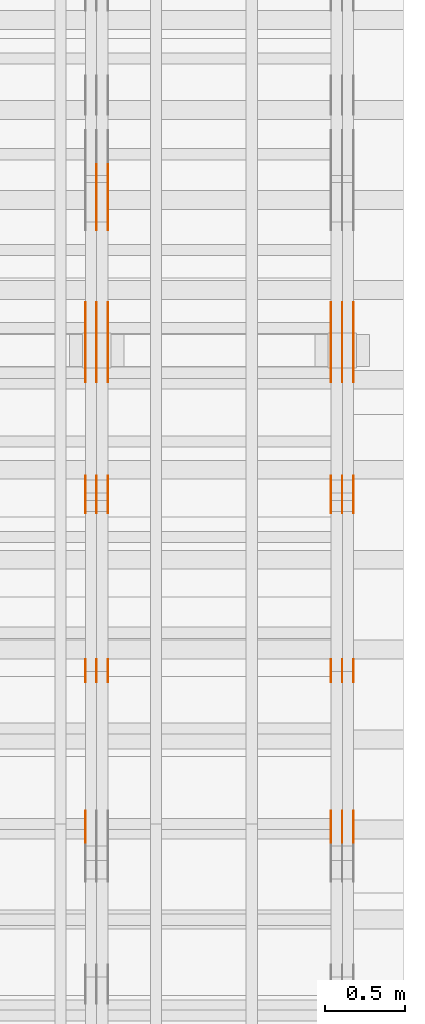
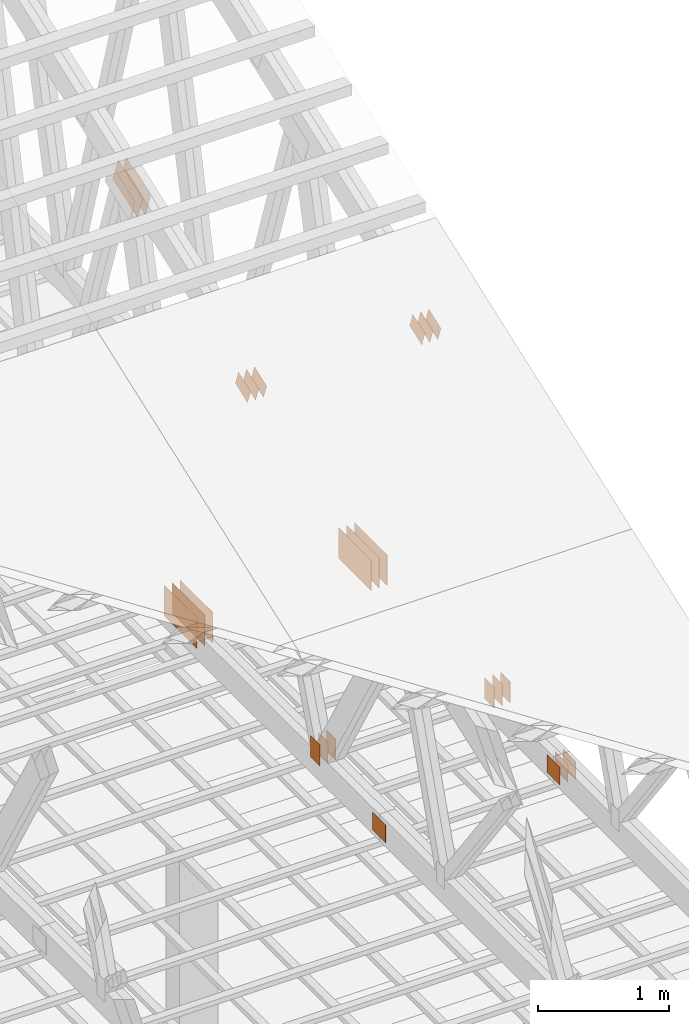
# One storey, part 156 of 189: 32 proxies.
"""IFC2X3 building model written with IfcOpenShell, lengths in millimetres."""

from ifc_helpers import new_model, entity, si_unit, converted_unit, derived_unit, direction, frame, frame_2d, origin, origin_2d_with_axis, place, context, subcontext, project, spatial, polyline, rectangle, outline, extrude, source, transform, mapped, material, type_object, type_shapes, element, save


model = new_model("IFC2X3")

# Units and contexts
model_context = context("Model", 3, precision=0.01, world=origin(), true_north=direction((6.12303176911189e-17, 1.0)))
body_context = subcontext(model_context, "Body", "Model", "MODEL_VIEW")
ifc_project = project(units=[si_unit("LENGTHUNIT", "METRE", prefix="MILLI"), si_unit("AREAUNIT", "SQUARE_METRE"), si_unit("VOLUMEUNIT", "CUBIC_METRE"), converted_unit("PLANEANGLEUNIT", "DEGREE", entity("IfcRatioMeasure", 0.0174532925199433), si_unit("PLANEANGLEUNIT", "RADIAN"), dimensions=[0, 0, 0, 0, 0, 0, 0]), si_unit("MASSUNIT", "GRAM", prefix="KILO"), derived_unit("MASSDENSITYUNIT", [(si_unit("MASSUNIT", "GRAM", prefix="KILO"), 1), (si_unit("LENGTHUNIT", "METRE"), -3)]), si_unit("TIMEUNIT", "SECOND"), si_unit("FREQUENCYUNIT", "HERTZ"), si_unit("THERMODYNAMICTEMPERATUREUNIT", "DEGREE_CELSIUS"), derived_unit("THERMALTRANSMITTANCEUNIT", [(si_unit("MASSUNIT", "GRAM", prefix="KILO"), 1), (si_unit("THERMODYNAMICTEMPERATUREUNIT", "KELVIN"), -1), (si_unit("TIMEUNIT", "SECOND"), -3)]), derived_unit("VOLUMETRICFLOWRATEUNIT", [(si_unit("LENGTHUNIT", "METRE"), 3), (si_unit("TIMEUNIT", "SECOND"), -1)]), si_unit("ELECTRICCURRENTUNIT", "AMPERE"), si_unit("ELECTRICVOLTAGEUNIT", "VOLT"), si_unit("POWERUNIT", "WATT"), si_unit("FORCEUNIT", "NEWTON"), si_unit("ILLUMINANCEUNIT", "LUX"), si_unit("LUMINOUSFLUXUNIT", "LUMEN"), si_unit("LUMINOUSINTENSITYUNIT", "CANDELA"), derived_unit("USERDEFINED", [(si_unit("MASSUNIT", "GRAM", prefix="KILO"), -1), (si_unit("LENGTHUNIT", "METRE"), -2), (si_unit("TIMEUNIT", "SECOND"), 3), (si_unit("LUMINOUSFLUXUNIT", "LUMEN"), 1)]), derived_unit("LINEARVELOCITYUNIT", [(si_unit("LENGTHUNIT", "METRE"), 1), (si_unit("TIMEUNIT", "SECOND"), -1)]), si_unit("PRESSUREUNIT", "PASCAL"), derived_unit("USERDEFINED", [(si_unit("LENGTHUNIT", "METRE"), -2), (si_unit("MASSUNIT", "GRAM", prefix="KILO"), 1), (si_unit("TIMEUNIT", "SECOND"), -2)])], contexts=[model_context])

# Site, building, storey
site_placement = place(None, origin())
site = spatial("IfcSite", under=ifc_project, at=site_placement, CompositionType="ELEMENT")
building_placement = place(site_placement, origin())
building = spatial("IfcBuilding", under=site, at=building_placement, CompositionType="ELEMENT")
storey_placement = place(building_placement, origin())
storey = spatial("IfcBuildingStorey", under=building, at=storey_placement, Name="Default", CompositionType="ELEMENT", Elevation=0.0)

# Proxies
ifc_material_1 = material(Name="IfcSurfaceStyle #284272")
building_element_proxy_type_1 = type_object("IfcBuildingElementProxyType", PredefinedType="NOTDEFINED", material=ifc_material_1)
shared_shape_1 = source(origin(), body_context, "Body", "SweptSolid", [
    extrude(rectangle(XDim=200.0, YDim=144.0, at=frame_2d((1.4210854715202e-14, 0.0), x_axis=(1.0, 0.0))), frame((100.0, 72.0, 0.0), z_axis=(0.0, 0.0, 1.0), x_axis=(-1.0, 0.0, 0.0)), (0.0, 0.0, 1.0), 1.3),
])
type_shapes(building_element_proxy_type_1, [shared_shape_1])
proxy_1_placement = place(building_placement, frame((49841.3, 6668.833984375, 145.0), z_axis=(-1.0, 0.0, 0.0), x_axis=(0.0, 0.0, 1.0)))
element("IfcBuildingElementProxy", 1, at=proxy_1_placement, inside=storey, type_object=building_element_proxy_type_1, material=ifc_material_1, context=body_context, shape_type="MappedRepresentation", body=[
    mapped(shared_shape_1, transform((0.0, 0.0, 0.0), scale=1.0)),
])
ifc_material_2 = material(Name="IfcSurfaceStyle #284215")
building_element_proxy_type_2 = type_object("IfcBuildingElementProxyType", PredefinedType="NOTDEFINED", material=ifc_material_2)
shared_shape_2 = source(origin(), body_context, "Body", "SweptSolid", [
    extrude(rectangle(XDim=200.0, YDim=144.0, at=frame_2d((1.4210854715202e-14, 0.0), x_axis=(1.0, 0.0))), frame((100.0, 72.0, 0.0), z_axis=(0.0, 0.0, 1.0), x_axis=(-1.0, 0.0, 0.0)), (0.0, 0.0, 1.0), 1.29999999999998),
])
type_shapes(building_element_proxy_type_2, [shared_shape_2])
proxy_2_placement = place(building_placement, frame((49770.0, 6668.833984375, 145.0), z_axis=(-1.0, 0.0, 0.0), x_axis=(0.0, 0.0, 1.0)))
element("IfcBuildingElementProxy", 2, at=proxy_2_placement, inside=storey, type_object=building_element_proxy_type_2, material=ifc_material_2, context=body_context, shape_type="MappedRepresentation", body=[
    mapped(shared_shape_2, transform((0.0, 0.0, 0.0), scale=1.0)),
])
ifc_material_3 = material(Name="IfcSurfaceStyle #284158")
building_element_proxy_type_3 = type_object("IfcBuildingElementProxyType", PredefinedType="NOTDEFINED", material=ifc_material_3)
shared_shape_3 = source(origin(), body_context, "Body", "SweptSolid", [
    extrude(rectangle(XDim=200.0, YDim=144.0, at=frame_2d((1.4210854715202e-14, 0.0), x_axis=(1.0, 0.0))), frame((100.0, 72.0, 0.0), z_axis=(0.0, 0.0, 1.0), x_axis=(-1.0, 0.0, 0.0)), (0.0, 0.0, 1.0), 1.29999999999998),
])
type_shapes(building_element_proxy_type_3, [shared_shape_3])
proxy_3_placement = place(building_placement, frame((49771.3, 6668.833984375, 145.0), z_axis=(-1.0, 0.0, 0.0), x_axis=(0.0, 0.0, 1.0)))
element("IfcBuildingElementProxy", 3, at=proxy_3_placement, inside=storey, type_object=building_element_proxy_type_3, material=ifc_material_3, context=body_context, shape_type="MappedRepresentation", body=[
    mapped(shared_shape_3, transform((0.0, 0.0, 0.0), scale=1.0)),
])
ifc_material_4 = material(Name="IfcSurfaceStyle #284101")
building_element_proxy_type_4 = type_object("IfcBuildingElementProxyType", PredefinedType="NOTDEFINED", material=ifc_material_4)
shared_shape_4 = source(origin(), body_context, "Body", "SweptSolid", [
    extrude(rectangle(XDim=200.0, YDim=144.0, at=frame_2d((1.4210854715202e-14, 0.0), x_axis=(1.0, 0.0))), frame((100.0, 72.0, 0.0), z_axis=(0.0, 0.0, 1.0), x_axis=(-1.0, 0.0, 0.0)), (0.0, 0.0, 1.0), 1.29999999999999),
])
type_shapes(building_element_proxy_type_4, [shared_shape_4])
proxy_4_placement = place(building_placement, frame((49700.0, 6668.833984375, 145.0), z_axis=(-1.0, 0.0, 0.0), x_axis=(0.0, 0.0, 1.0)))
element("IfcBuildingElementProxy", 4, at=proxy_4_placement, inside=storey, type_object=building_element_proxy_type_4, material=ifc_material_4, context=body_context, shape_type="MappedRepresentation", body=[
    mapped(shared_shape_4, transform((0.0, 0.0, 0.0), scale=1.0)),
])
ifc_material_5 = material(Name="IfcSurfaceStyle #284044")
building_element_proxy_type_5 = type_object("IfcBuildingElementProxyType", PredefinedType="NOTDEFINED", material=ifc_material_5)
shared_shape_5 = source(origin(), body_context, "Body", "SweptSolid", [
    extrude(rectangle(XDim=200.0, YDim=168.0, at=origin_2d_with_axis()), frame((100.0, 84.0, 0.0), z_axis=(0.0, 0.0, 1.0), x_axis=(-1.0, 0.0, 0.0)), (0.0, 0.0, 1.0), 1.3),
])
type_shapes(building_element_proxy_type_5, [shared_shape_5])
proxy_5_placement = place(building_placement, frame((49841.3, 5662.466796875, 206.5), z_axis=(-1.0, 0.0, 0.0), x_axis=(0.0, 1.0, 0.0)))
element("IfcBuildingElementProxy", 5, at=proxy_5_placement, inside=storey, type_object=building_element_proxy_type_5, material=ifc_material_5, context=body_context, shape_type="MappedRepresentation", body=[
    mapped(shared_shape_5, transform((0.0, 0.0, 0.0), scale=1.0)),
])
ifc_material_6 = material(Name="IfcSurfaceStyle #283987")
building_element_proxy_type_6 = type_object("IfcBuildingElementProxyType", PredefinedType="NOTDEFINED", material=ifc_material_6)
shared_shape_6 = source(origin(), body_context, "Body", "SweptSolid", [
    extrude(rectangle(XDim=200.0, YDim=168.0, at=origin_2d_with_axis()), frame((100.0, 84.0, 0.0), z_axis=(0.0, 0.0, 1.0), x_axis=(-1.0, 0.0, 0.0)), (0.0, 0.0, 1.0), 1.29999999999998),
])
type_shapes(building_element_proxy_type_6, [shared_shape_6])
proxy_6_placement = place(building_placement, frame((49770.0, 5662.466796875, 206.5), z_axis=(-1.0, 0.0, 0.0), x_axis=(0.0, 1.0, 0.0)))
element("IfcBuildingElementProxy", 6, at=proxy_6_placement, inside=storey, type_object=building_element_proxy_type_6, material=ifc_material_6, context=body_context, shape_type="MappedRepresentation", body=[
    mapped(shared_shape_6, transform((0.0, 0.0, 0.0), scale=1.0)),
])
ifc_material_7 = material(Name="IfcSurfaceStyle #283930")
building_element_proxy_type_7 = type_object("IfcBuildingElementProxyType", PredefinedType="NOTDEFINED", material=ifc_material_7)
shared_shape_7 = source(origin(), body_context, "Body", "SweptSolid", [
    extrude(rectangle(XDim=200.0, YDim=168.0, at=origin_2d_with_axis()), frame((100.0, 84.0, 0.0), z_axis=(0.0, 0.0, 1.0), x_axis=(-1.0, 0.0, 0.0)), (0.0, 0.0, 1.0), 1.29999999999998),
])
type_shapes(building_element_proxy_type_7, [shared_shape_7])
proxy_7_placement = place(building_placement, frame((49771.3, 5662.466796875, 206.5), z_axis=(-1.0, 0.0, 0.0), x_axis=(0.0, 1.0, 0.0)))
element("IfcBuildingElementProxy", 7, at=proxy_7_placement, inside=storey, type_object=building_element_proxy_type_7, material=ifc_material_7, context=body_context, shape_type="MappedRepresentation", body=[
    mapped(shared_shape_7, transform((0.0, 0.0, 0.0), scale=1.0)),
])
ifc_material_8 = material(Name="IfcSurfaceStyle #283873")
building_element_proxy_type_8 = type_object("IfcBuildingElementProxyType", PredefinedType="NOTDEFINED", material=ifc_material_8)
shared_shape_8 = source(origin(), body_context, "Body", "SweptSolid", [
    extrude(rectangle(XDim=200.0, YDim=168.0, at=origin_2d_with_axis()), frame((100.0, 84.0, 0.0), z_axis=(0.0, 0.0, 1.0), x_axis=(-1.0, 0.0, 0.0)), (0.0, 0.0, 1.0), 1.29999999999999),
])
type_shapes(building_element_proxy_type_8, [shared_shape_8])
proxy_8_placement = place(building_placement, frame((49700.0, 5662.466796875, 206.5), z_axis=(-1.0, 0.0, 0.0), x_axis=(0.0, 1.0, 0.0)))
element("IfcBuildingElementProxy", 8, at=proxy_8_placement, inside=storey, type_object=building_element_proxy_type_8, material=ifc_material_8, context=body_context, shape_type="MappedRepresentation", body=[
    mapped(shared_shape_8, transform((0.0, 0.0, 0.0), scale=1.0)),
])
ifc_material_9 = material(Name="IfcSurfaceStyle #281308")
building_element_proxy_type_9 = type_object("IfcBuildingElementProxyType", PredefinedType="NOTDEFINED", material=ifc_material_9)
shared_shape_9 = source(origin(), body_context, "Body", "SweptSolid", [
    extrude(rectangle(XDim=500.0, YDim=288.0, at=frame_2d((0.0, 1.4210854715202e-14), x_axis=(1.0, 0.0))), frame((250.000973740011, 144.0, 0.0), z_axis=(0.0, 0.0, 1.0), x_axis=(-1.0, 0.0, 0.0)), (0.0, 0.0, 1.0), 1.29999999999998),
])
type_shapes(building_element_proxy_type_9, [shared_shape_9])
proxy_9_placement = place(building_placement, frame((49841.3, 8551.90918250999, 389.0), z_axis=(-1.0, 0.0, 0.0), x_axis=(0.0, 1.0, 0.0)))
element("IfcBuildingElementProxy", 9, at=proxy_9_placement, inside=storey, type_object=building_element_proxy_type_9, material=ifc_material_9, context=body_context, shape_type="MappedRepresentation", body=[
    mapped(shared_shape_9, transform((0.0, 0.0, 0.0), scale=1.0)),
])
ifc_material_10 = material(Name="IfcSurfaceStyle #281251")
building_element_proxy_type_10 = type_object("IfcBuildingElementProxyType", PredefinedType="NOTDEFINED", material=ifc_material_10)
shared_shape_10 = source(origin(), body_context, "Body", "SweptSolid", [
    extrude(rectangle(XDim=500.0, YDim=288.0, at=frame_2d((0.0, 1.4210854715202e-14), x_axis=(1.0, 0.0))), frame((250.000973740011, 144.0, 0.0), z_axis=(0.0, 0.0, 1.0), x_axis=(-1.0, 0.0, 0.0)), (0.0, 0.0, 1.0), 1.29999999999997),
])
type_shapes(building_element_proxy_type_10, [shared_shape_10])
proxy_10_placement = place(building_placement, frame((49770.0, 8551.90918250999, 389.0), z_axis=(-1.0, 0.0, 0.0), x_axis=(0.0, 1.0, 0.0)))
element("IfcBuildingElementProxy", 10, at=proxy_10_placement, inside=storey, type_object=building_element_proxy_type_10, material=ifc_material_10, context=body_context, shape_type="MappedRepresentation", body=[
    mapped(shared_shape_10, transform((0.0, 0.0, 0.0), scale=1.0)),
])
ifc_material_11 = material(Name="IfcSurfaceStyle #281194")
building_element_proxy_type_11 = type_object("IfcBuildingElementProxyType", PredefinedType="NOTDEFINED", material=ifc_material_11)
shared_shape_11 = source(origin(), body_context, "Body", "SweptSolid", [
    extrude(rectangle(XDim=500.0, YDim=288.0, at=frame_2d((0.0, 1.4210854715202e-14), x_axis=(1.0, 0.0))), frame((250.000973740011, 144.0, 0.0), z_axis=(0.0, 0.0, 1.0), x_axis=(-1.0, 0.0, 0.0)), (0.0, 0.0, 1.0), 1.29999999999997),
])
type_shapes(building_element_proxy_type_11, [shared_shape_11])
proxy_11_placement = place(building_placement, frame((49771.3, 8551.90918250999, 389.0), z_axis=(-1.0, 0.0, 0.0), x_axis=(0.0, 1.0, 0.0)))
element("IfcBuildingElementProxy", 11, at=proxy_11_placement, inside=storey, type_object=building_element_proxy_type_11, material=ifc_material_11, context=body_context, shape_type="MappedRepresentation", body=[
    mapped(shared_shape_11, transform((0.0, 0.0, 0.0), scale=1.0)),
])
ifc_material_12 = material(Name="IfcSurfaceStyle #281137")
building_element_proxy_type_12 = type_object("IfcBuildingElementProxyType", PredefinedType="NOTDEFINED", material=ifc_material_12)
shared_shape_12 = source(origin(), body_context, "Body", "SweptSolid", [
    extrude(rectangle(XDim=500.0, YDim=288.0, at=frame_2d((0.0, 1.4210854715202e-14), x_axis=(1.0, 0.0))), frame((250.000973740011, 144.0, 0.0), z_axis=(0.0, 0.0, 1.0), x_axis=(-1.0, 0.0, 0.0)), (0.0, 0.0, 1.0), 1.29999999999997),
])
type_shapes(building_element_proxy_type_12, [shared_shape_12])
proxy_12_placement = place(building_placement, frame((49700.0, 8551.90918250999, 389.0), z_axis=(-1.0, 0.0, 0.0), x_axis=(0.0, 1.0, 0.0)))
element("IfcBuildingElementProxy", 12, at=proxy_12_placement, inside=storey, type_object=building_element_proxy_type_12, material=ifc_material_12, context=body_context, shape_type="MappedRepresentation", body=[
    mapped(shared_shape_12, transform((0.0, 0.0, 0.0), scale=1.0)),
])
ifc_material_13 = material(Name="IfcSurfaceStyle #281080")
building_element_proxy_type_13 = type_object("IfcBuildingElementProxyType", PredefinedType="NOTDEFINED", material=ifc_material_13)
shared_shape_13 = source(origin(), body_context, "Body", "SweptSolid", [
    extrude(outline(polyline([(-100.00048713087, -72.0000025659129), (100.000394045495, -72.0000025659129), (99.9995694622958, 72.0000025659129), (-99.9994763769209, 72.0000025659128), (-100.00048713087, -72.0000025659129)])), frame((100.000394045495, 72.0000025659128, 0.0), z_axis=(0.0, 0.0, 1.0), x_axis=(-1.0, 0.0, 0.0)), (0.0, 0.0, 1.0), 1.3),
])
type_shapes(building_element_proxy_type_13, [shared_shape_13])
proxy_13_placement = place(building_placement, frame((49841.3, 7965.16887114408, 2936.19963864386), z_axis=(-1.0, 0.0, 0.0), x_axis=(0.0, -0.939692620785908, -0.342020143325669)))
element("IfcBuildingElementProxy", 13, at=proxy_13_placement, inside=storey, type_object=building_element_proxy_type_13, material=ifc_material_13, context=body_context, shape_type="MappedRepresentation", body=[
    mapped(shared_shape_13, transform((0.0, 0.0, 0.0), scale=1.0)),
])
ifc_material_14 = material(Name="IfcSurfaceStyle #281023")
building_element_proxy_type_14 = type_object("IfcBuildingElementProxyType", PredefinedType="NOTDEFINED", material=ifc_material_14)
shared_shape_14 = source(origin(), body_context, "Body", "SweptSolid", [
    extrude(outline(polyline([(-100.00048713087, -72.0000025659129), (100.000394045495, -72.0000025659129), (99.9995694622958, 72.0000025659129), (-99.9994763769209, 72.0000025659128), (-100.00048713087, -72.0000025659129)])), frame((100.000394045495, 72.0000025659128, 0.0), z_axis=(0.0, 0.0, 1.0), x_axis=(-1.0, 0.0, 0.0)), (0.0, 0.0, 1.0), 1.29999999999998),
])
type_shapes(building_element_proxy_type_14, [shared_shape_14])
proxy_14_placement = place(building_placement, frame((49770.0, 7965.16887114408, 2936.19963864386), z_axis=(-1.0, 0.0, 0.0), x_axis=(0.0, -0.939692620785908, -0.342020143325669)))
element("IfcBuildingElementProxy", 14, at=proxy_14_placement, inside=storey, type_object=building_element_proxy_type_14, material=ifc_material_14, context=body_context, shape_type="MappedRepresentation", body=[
    mapped(shared_shape_14, transform((0.0, 0.0, 0.0), scale=1.0)),
])
ifc_material_15 = material(Name="IfcSurfaceStyle #280966")
building_element_proxy_type_15 = type_object("IfcBuildingElementProxyType", PredefinedType="NOTDEFINED", material=ifc_material_15)
shared_shape_15 = source(origin(), body_context, "Body", "SweptSolid", [
    extrude(outline(polyline([(-100.00048713087, -72.0000025659129), (100.000394045495, -72.0000025659129), (99.9995694622958, 72.0000025659129), (-99.9994763769209, 72.0000025659128), (-100.00048713087, -72.0000025659129)])), frame((100.000394045495, 72.0000025659128, 0.0), z_axis=(0.0, 0.0, 1.0), x_axis=(-1.0, 0.0, 0.0)), (0.0, 0.0, 1.0), 1.29999999999998),
])
type_shapes(building_element_proxy_type_15, [shared_shape_15])
proxy_15_placement = place(building_placement, frame((49771.3, 7965.16887114408, 2936.19963864386), z_axis=(-1.0, 0.0, 0.0), x_axis=(0.0, -0.939692620785908, -0.342020143325669)))
element("IfcBuildingElementProxy", 15, at=proxy_15_placement, inside=storey, type_object=building_element_proxy_type_15, material=ifc_material_15, context=body_context, shape_type="MappedRepresentation", body=[
    mapped(shared_shape_15, transform((0.0, 0.0, 0.0), scale=1.0)),
])
ifc_material_16 = material(Name="IfcSurfaceStyle #280909")
building_element_proxy_type_16 = type_object("IfcBuildingElementProxyType", PredefinedType="NOTDEFINED", material=ifc_material_16)
shared_shape_16 = source(origin(), body_context, "Body", "SweptSolid", [
    extrude(outline(polyline([(-100.00048713087, -72.0000025659129), (100.000394045495, -72.0000025659129), (99.9995694622958, 72.0000025659129), (-99.9994763769209, 72.0000025659128), (-100.00048713087, -72.0000025659129)])), frame((100.000394045495, 72.0000025659128, 0.0), z_axis=(0.0, 0.0, 1.0), x_axis=(-1.0, 0.0, 0.0)), (0.0, 0.0, 1.0), 1.29999999999999),
])
type_shapes(building_element_proxy_type_16, [shared_shape_16])
proxy_16_placement = place(building_placement, frame((49700.0, 7965.16887114408, 2936.19963864386), z_axis=(-1.0, 0.0, 0.0), x_axis=(0.0, -0.939692620785908, -0.342020143325669)))
element("IfcBuildingElementProxy", 16, at=proxy_16_placement, inside=storey, type_object=building_element_proxy_type_16, material=ifc_material_16, context=body_context, shape_type="MappedRepresentation", body=[
    mapped(shared_shape_16, transform((0.0, 0.0, 0.0), scale=1.0)),
])
ifc_material_17 = material(Name="IfcSurfaceStyle #268482")
building_element_proxy_type_17 = type_object("IfcBuildingElementProxyType", PredefinedType="NOTDEFINED", material=ifc_material_17)
shared_shape_17 = source(origin(), body_context, "Body", "SweptSolid", [
    extrude(rectangle(XDim=200.0, YDim=144.0, at=frame_2d((1.4210854715202e-14, 0.0), x_axis=(1.0, 0.0))), frame((100.0, 72.0, 0.0), z_axis=(0.0, 0.0, 1.0), x_axis=(-1.0, 0.0, 0.0)), (0.0, 0.0, 1.0), 1.3),
])
type_shapes(building_element_proxy_type_17, [shared_shape_17])
proxy_17_placement = place(building_placement, frame((48301.3, 6668.833984375, 145.0), z_axis=(-1.0, 0.0, 0.0), x_axis=(0.0, 0.0, 1.0)))
element("IfcBuildingElementProxy", 17, at=proxy_17_placement, inside=storey, type_object=building_element_proxy_type_17, material=ifc_material_17, context=body_context, shape_type="MappedRepresentation", body=[
    mapped(shared_shape_17, transform((0.0, 0.0, 0.0), scale=1.0)),
])
ifc_material_18 = material(Name="IfcSurfaceStyle #268425")
building_element_proxy_type_18 = type_object("IfcBuildingElementProxyType", PredefinedType="NOTDEFINED", material=ifc_material_18)
shared_shape_18 = source(origin(), body_context, "Body", "SweptSolid", [
    extrude(rectangle(XDim=200.0, YDim=144.0, at=frame_2d((1.4210854715202e-14, 0.0), x_axis=(1.0, 0.0))), frame((100.0, 72.0, 0.0), z_axis=(0.0, 0.0, 1.0), x_axis=(-1.0, 0.0, 0.0)), (0.0, 0.0, 1.0), 1.29999999999998),
])
type_shapes(building_element_proxy_type_18, [shared_shape_18])
proxy_18_placement = place(building_placement, frame((48230.0, 6668.833984375, 145.0), z_axis=(-1.0, 0.0, 0.0), x_axis=(0.0, 0.0, 1.0)))
element("IfcBuildingElementProxy", 18, at=proxy_18_placement, inside=storey, type_object=building_element_proxy_type_18, material=ifc_material_18, context=body_context, shape_type="MappedRepresentation", body=[
    mapped(shared_shape_18, transform((0.0, 0.0, 0.0), scale=1.0)),
])
ifc_material_19 = material(Name="IfcSurfaceStyle #268368")
building_element_proxy_type_19 = type_object("IfcBuildingElementProxyType", PredefinedType="NOTDEFINED", material=ifc_material_19)
shared_shape_19 = source(origin(), body_context, "Body", "SweptSolid", [
    extrude(rectangle(XDim=200.0, YDim=144.0, at=frame_2d((1.4210854715202e-14, 0.0), x_axis=(1.0, 0.0))), frame((100.0, 72.0, 0.0), z_axis=(0.0, 0.0, 1.0), x_axis=(-1.0, 0.0, 0.0)), (0.0, 0.0, 1.0), 1.29999999999998),
])
type_shapes(building_element_proxy_type_19, [shared_shape_19])
proxy_19_placement = place(building_placement, frame((48231.3, 6668.833984375, 145.0), z_axis=(-1.0, 0.0, 0.0), x_axis=(0.0, 0.0, 1.0)))
element("IfcBuildingElementProxy", 19, at=proxy_19_placement, inside=storey, type_object=building_element_proxy_type_19, material=ifc_material_19, context=body_context, shape_type="MappedRepresentation", body=[
    mapped(shared_shape_19, transform((0.0, 0.0, 0.0), scale=1.0)),
])
ifc_material_20 = material(Name="IfcSurfaceStyle #268311")
building_element_proxy_type_20 = type_object("IfcBuildingElementProxyType", PredefinedType="NOTDEFINED", material=ifc_material_20)
shared_shape_20 = source(origin(), body_context, "Body", "SweptSolid", [
    extrude(rectangle(XDim=200.0, YDim=144.0, at=frame_2d((1.4210854715202e-14, 0.0), x_axis=(1.0, 0.0))), frame((100.0, 72.0, 0.0), z_axis=(0.0, 0.0, 1.0), x_axis=(-1.0, 0.0, 0.0)), (0.0, 0.0, 1.0), 1.29999999999999),
])
type_shapes(building_element_proxy_type_20, [shared_shape_20])
proxy_20_placement = place(building_placement, frame((48160.0, 6668.833984375, 145.0), z_axis=(-1.0, 0.0, 0.0), x_axis=(0.0, 0.0, 1.0)))
element("IfcBuildingElementProxy", 20, at=proxy_20_placement, inside=storey, type_object=building_element_proxy_type_20, material=ifc_material_20, context=body_context, shape_type="MappedRepresentation", body=[
    mapped(shared_shape_20, transform((0.0, 0.0, 0.0), scale=1.0)),
])
ifc_material_21 = material(Name="IfcSurfaceStyle #268083")
building_element_proxy_type_21 = type_object("IfcBuildingElementProxyType", PredefinedType="NOTDEFINED", material=ifc_material_21)
shared_shape_21 = source(origin(), body_context, "Body", "SweptSolid", [
    extrude(rectangle(XDim=200.0, YDim=168.0, at=origin_2d_with_axis()), frame((100.0, 84.0, 0.0), z_axis=(0.0, 0.0, 1.0), x_axis=(-1.0, 0.0, 0.0)), (0.0, 0.0, 1.0), 1.29999999999999),
])
type_shapes(building_element_proxy_type_21, [shared_shape_21])
proxy_21_placement = place(building_placement, frame((48160.0, 5662.466796875, 206.5), z_axis=(-1.0, 0.0, 0.0), x_axis=(0.0, 1.0, 0.0)))
element("IfcBuildingElementProxy", 21, at=proxy_21_placement, inside=storey, type_object=building_element_proxy_type_21, material=ifc_material_21, context=body_context, shape_type="MappedRepresentation", body=[
    mapped(shared_shape_21, transform((0.0, 0.0, 0.0), scale=1.0)),
])
ifc_material_22 = material(Name="IfcSurfaceStyle #266202")
building_element_proxy_type_22 = type_object("IfcBuildingElementProxyType", PredefinedType="NOTDEFINED", material=ifc_material_22)
shared_shape_22 = source(origin(), body_context, "Body", "SweptSolid", [
    extrude(outline(polyline([(-199.999582244654, -119.99984375717), (200.000344770932, -119.99984375717), (199.999582244655, 119.99984375717), (-200.000344770934, 119.99984375717), (-199.999582244654, -119.99984375717)])), frame((200.000344770932, 120.0000091947, 0.0), z_axis=(0.0, 0.0, 1.0), x_axis=(-1.0, 0.0, 0.0)), (0.0, 0.0, 1.0), 1.29999999999999),
])
type_shapes(building_element_proxy_type_22, [shared_shape_22])
proxy_22_placement = place(building_placement, frame((48301.3, 9961.90704972973, 3612.2451494258), z_axis=(-1.0, 0.0, 0.0), x_axis=(0.0, -0.939692620785908, -0.342020143325669)))
element("IfcBuildingElementProxy", 22, at=proxy_22_placement, inside=storey, type_object=building_element_proxy_type_22, material=ifc_material_22, context=body_context, shape_type="MappedRepresentation", body=[
    mapped(shared_shape_22, transform((0.0, 0.0, 0.0), scale=1.0)),
])
ifc_material_23 = material(Name="IfcSurfaceStyle #266145")
building_element_proxy_type_23 = type_object("IfcBuildingElementProxyType", PredefinedType="NOTDEFINED", material=ifc_material_23)
shared_shape_23 = source(origin(), body_context, "Body", "SweptSolid", [
    extrude(outline(polyline([(-199.999582244654, -119.99984375717), (200.000344770932, -119.99984375717), (199.999582244655, 119.99984375717), (-200.000344770934, 119.99984375717), (-199.999582244654, -119.99984375717)])), frame((200.000344770932, 120.0000091947, 0.0), z_axis=(0.0, 0.0, 1.0), x_axis=(-1.0, 0.0, 0.0)), (0.0, 0.0, 1.0), 1.29999999999997),
])
type_shapes(building_element_proxy_type_23, [shared_shape_23])
proxy_23_placement = place(building_placement, frame((48230.0, 9961.90704972973, 3612.2451494258), z_axis=(-1.0, 0.0, 0.0), x_axis=(0.0, -0.939692620785908, -0.342020143325669)))
element("IfcBuildingElementProxy", 23, at=proxy_23_placement, inside=storey, type_object=building_element_proxy_type_23, material=ifc_material_23, context=body_context, shape_type="MappedRepresentation", body=[
    mapped(shared_shape_23, transform((0.0, 0.0, 0.0), scale=1.0)),
])
ifc_material_24 = material(Name="IfcSurfaceStyle #266088")
building_element_proxy_type_24 = type_object("IfcBuildingElementProxyType", PredefinedType="NOTDEFINED", material=ifc_material_24)
shared_shape_24 = source(origin(), body_context, "Body", "SweptSolid", [
    extrude(outline(polyline([(-199.999582244654, -119.99984375717), (200.000344770932, -119.99984375717), (199.999582244655, 119.99984375717), (-200.000344770934, 119.99984375717), (-199.999582244654, -119.99984375717)])), frame((200.000344770932, 120.0000091947, 0.0), z_axis=(0.0, 0.0, 1.0), x_axis=(-1.0, 0.0, 0.0)), (0.0, 0.0, 1.0), 1.29999999999997),
])
type_shapes(building_element_proxy_type_24, [shared_shape_24])
proxy_24_placement = place(building_placement, frame((48231.3, 9961.90704972973, 3612.2451494258), z_axis=(-1.0, 0.0, 0.0), x_axis=(0.0, -0.939692620785908, -0.342020143325669)))
element("IfcBuildingElementProxy", 24, at=proxy_24_placement, inside=storey, type_object=building_element_proxy_type_24, material=ifc_material_24, context=body_context, shape_type="MappedRepresentation", body=[
    mapped(shared_shape_24, transform((0.0, 0.0, 0.0), scale=1.0)),
])
ifc_material_25 = material(Name="IfcSurfaceStyle #265518")
building_element_proxy_type_25 = type_object("IfcBuildingElementProxyType", PredefinedType="NOTDEFINED", material=ifc_material_25)
shared_shape_25 = source(origin(), body_context, "Body", "SweptSolid", [
    extrude(rectangle(XDim=500.0, YDim=288.0, at=frame_2d((0.0, 1.4210854715202e-14), x_axis=(1.0, 0.0))), frame((250.000973740011, 144.0, 0.0), z_axis=(0.0, 0.0, 1.0), x_axis=(-1.0, 0.0, 0.0)), (0.0, 0.0, 1.0), 1.29999999999998),
])
type_shapes(building_element_proxy_type_25, [shared_shape_25])
proxy_25_placement = place(building_placement, frame((48301.3, 8551.90918250999, 389.0), z_axis=(-1.0, 0.0, 0.0), x_axis=(0.0, 1.0, 0.0)))
element("IfcBuildingElementProxy", 25, at=proxy_25_placement, inside=storey, type_object=building_element_proxy_type_25, material=ifc_material_25, context=body_context, shape_type="MappedRepresentation", body=[
    mapped(shared_shape_25, transform((0.0, 0.0, 0.0), scale=1.0)),
])
ifc_material_26 = material(Name="IfcSurfaceStyle #265461")
building_element_proxy_type_26 = type_object("IfcBuildingElementProxyType", PredefinedType="NOTDEFINED", material=ifc_material_26)
shared_shape_26 = source(origin(), body_context, "Body", "SweptSolid", [
    extrude(rectangle(XDim=500.0, YDim=288.0, at=frame_2d((0.0, 1.4210854715202e-14), x_axis=(1.0, 0.0))), frame((250.000973740011, 144.0, 0.0), z_axis=(0.0, 0.0, 1.0), x_axis=(-1.0, 0.0, 0.0)), (0.0, 0.0, 1.0), 1.29999999999997),
])
type_shapes(building_element_proxy_type_26, [shared_shape_26])
proxy_26_placement = place(building_placement, frame((48230.0, 8551.90918250999, 389.0), z_axis=(-1.0, 0.0, 0.0), x_axis=(0.0, 1.0, 0.0)))
element("IfcBuildingElementProxy", 26, at=proxy_26_placement, inside=storey, type_object=building_element_proxy_type_26, material=ifc_material_26, context=body_context, shape_type="MappedRepresentation", body=[
    mapped(shared_shape_26, transform((0.0, 0.0, 0.0), scale=1.0)),
])
ifc_material_27 = material(Name="IfcSurfaceStyle #265404")
building_element_proxy_type_27 = type_object("IfcBuildingElementProxyType", PredefinedType="NOTDEFINED", material=ifc_material_27)
shared_shape_27 = source(origin(), body_context, "Body", "SweptSolid", [
    extrude(rectangle(XDim=500.0, YDim=288.0, at=frame_2d((0.0, 1.4210854715202e-14), x_axis=(1.0, 0.0))), frame((250.000973740011, 144.0, 0.0), z_axis=(0.0, 0.0, 1.0), x_axis=(-1.0, 0.0, 0.0)), (0.0, 0.0, 1.0), 1.29999999999997),
])
type_shapes(building_element_proxy_type_27, [shared_shape_27])
proxy_27_placement = place(building_placement, frame((48231.3, 8551.90918250999, 389.0), z_axis=(-1.0, 0.0, 0.0), x_axis=(0.0, 1.0, 0.0)))
element("IfcBuildingElementProxy", 27, at=proxy_27_placement, inside=storey, type_object=building_element_proxy_type_27, material=ifc_material_27, context=body_context, shape_type="MappedRepresentation", body=[
    mapped(shared_shape_27, transform((0.0, 0.0, 0.0), scale=1.0)),
])
ifc_material_28 = material(Name="IfcSurfaceStyle #265347")
building_element_proxy_type_28 = type_object("IfcBuildingElementProxyType", PredefinedType="NOTDEFINED", material=ifc_material_28)
shared_shape_28 = source(origin(), body_context, "Body", "SweptSolid", [
    extrude(rectangle(XDim=500.0, YDim=288.0, at=frame_2d((0.0, 1.4210854715202e-14), x_axis=(1.0, 0.0))), frame((250.000973740011, 144.0, 0.0), z_axis=(0.0, 0.0, 1.0), x_axis=(-1.0, 0.0, 0.0)), (0.0, 0.0, 1.0), 1.29999999999997),
])
type_shapes(building_element_proxy_type_28, [shared_shape_28])
proxy_28_placement = place(building_placement, frame((48160.0, 8551.90918250999, 389.0), z_axis=(-1.0, 0.0, 0.0), x_axis=(0.0, 1.0, 0.0)))
element("IfcBuildingElementProxy", 28, at=proxy_28_placement, inside=storey, type_object=building_element_proxy_type_28, material=ifc_material_28, context=body_context, shape_type="MappedRepresentation", body=[
    mapped(shared_shape_28, transform((0.0, 0.0, 0.0), scale=1.0)),
])
ifc_material_29 = material(Name="IfcSurfaceStyle #265290")
building_element_proxy_type_29 = type_object("IfcBuildingElementProxyType", PredefinedType="NOTDEFINED", material=ifc_material_29)
shared_shape_29 = source(origin(), body_context, "Body", "SweptSolid", [
    extrude(outline(polyline([(-100.00048713087, -72.0000025659129), (100.000394045495, -72.0000025659129), (99.9995694622958, 72.0000025659129), (-99.9994763769209, 72.0000025659128), (-100.00048713087, -72.0000025659129)])), frame((100.000394045495, 72.0000025659128, 0.0), z_axis=(0.0, 0.0, 1.0), x_axis=(-1.0, 0.0, 0.0)), (0.0, 0.0, 1.0), 1.3),
])
type_shapes(building_element_proxy_type_29, [shared_shape_29])
proxy_29_placement = place(building_placement, frame((48301.3, 7965.16887114408, 2936.19963864386), z_axis=(-1.0, 0.0, 0.0), x_axis=(0.0, -0.939692620785908, -0.342020143325669)))
element("IfcBuildingElementProxy", 29, at=proxy_29_placement, inside=storey, type_object=building_element_proxy_type_29, material=ifc_material_29, context=body_context, shape_type="MappedRepresentation", body=[
    mapped(shared_shape_29, transform((0.0, 0.0, 0.0), scale=1.0)),
])
ifc_material_30 = material(Name="IfcSurfaceStyle #265233")
building_element_proxy_type_30 = type_object("IfcBuildingElementProxyType", PredefinedType="NOTDEFINED", material=ifc_material_30)
shared_shape_30 = source(origin(), body_context, "Body", "SweptSolid", [
    extrude(outline(polyline([(-100.00048713087, -72.0000025659129), (100.000394045495, -72.0000025659129), (99.9995694622958, 72.0000025659129), (-99.9994763769209, 72.0000025659128), (-100.00048713087, -72.0000025659129)])), frame((100.000394045495, 72.0000025659128, 0.0), z_axis=(0.0, 0.0, 1.0), x_axis=(-1.0, 0.0, 0.0)), (0.0, 0.0, 1.0), 1.29999999999998),
])
type_shapes(building_element_proxy_type_30, [shared_shape_30])
proxy_30_placement = place(building_placement, frame((48230.0, 7965.16887114408, 2936.19963864386), z_axis=(-1.0, 0.0, 0.0), x_axis=(0.0, -0.939692620785908, -0.342020143325669)))
element("IfcBuildingElementProxy", 30, at=proxy_30_placement, inside=storey, type_object=building_element_proxy_type_30, material=ifc_material_30, context=body_context, shape_type="MappedRepresentation", body=[
    mapped(shared_shape_30, transform((0.0, 0.0, 0.0), scale=1.0)),
])
ifc_material_31 = material(Name="IfcSurfaceStyle #265176")
building_element_proxy_type_31 = type_object("IfcBuildingElementProxyType", PredefinedType="NOTDEFINED", material=ifc_material_31)
shared_shape_31 = source(origin(), body_context, "Body", "SweptSolid", [
    extrude(outline(polyline([(-100.00048713087, -72.0000025659129), (100.000394045495, -72.0000025659129), (99.9995694622958, 72.0000025659129), (-99.9994763769209, 72.0000025659128), (-100.00048713087, -72.0000025659129)])), frame((100.000394045495, 72.0000025659128, 0.0), z_axis=(0.0, 0.0, 1.0), x_axis=(-1.0, 0.0, 0.0)), (0.0, 0.0, 1.0), 1.29999999999998),
])
type_shapes(building_element_proxy_type_31, [shared_shape_31])
proxy_31_placement = place(building_placement, frame((48231.3, 7965.16887114408, 2936.19963864386), z_axis=(-1.0, 0.0, 0.0), x_axis=(0.0, -0.939692620785908, -0.342020143325669)))
element("IfcBuildingElementProxy", 31, at=proxy_31_placement, inside=storey, type_object=building_element_proxy_type_31, material=ifc_material_31, context=body_context, shape_type="MappedRepresentation", body=[
    mapped(shared_shape_31, transform((0.0, 0.0, 0.0), scale=1.0)),
])
ifc_material_32 = material(Name="IfcSurfaceStyle #265119")
building_element_proxy_type_32 = type_object("IfcBuildingElementProxyType", PredefinedType="NOTDEFINED", material=ifc_material_32)
shared_shape_32 = source(origin(), body_context, "Body", "SweptSolid", [
    extrude(outline(polyline([(-100.00048713087, -72.0000025659129), (100.000394045495, -72.0000025659129), (99.9995694622958, 72.0000025659129), (-99.9994763769209, 72.0000025659128), (-100.00048713087, -72.0000025659129)])), frame((100.000394045495, 72.0000025659128, 0.0), z_axis=(0.0, 0.0, 1.0), x_axis=(-1.0, 0.0, 0.0)), (0.0, 0.0, 1.0), 1.29999999999999),
])
type_shapes(building_element_proxy_type_32, [shared_shape_32])
proxy_32_placement = place(building_placement, frame((48160.0, 7965.16887114408, 2936.19963864386), z_axis=(-1.0, 0.0, 0.0), x_axis=(0.0, -0.939692620785908, -0.342020143325669)))
element("IfcBuildingElementProxy", 32, at=proxy_32_placement, inside=storey, type_object=building_element_proxy_type_32, material=ifc_material_32, context=body_context, shape_type="MappedRepresentation", body=[
    mapped(shared_shape_32, transform((0.0, 0.0, 0.0), scale=1.0)),
])

save(model, "model.ifc")
